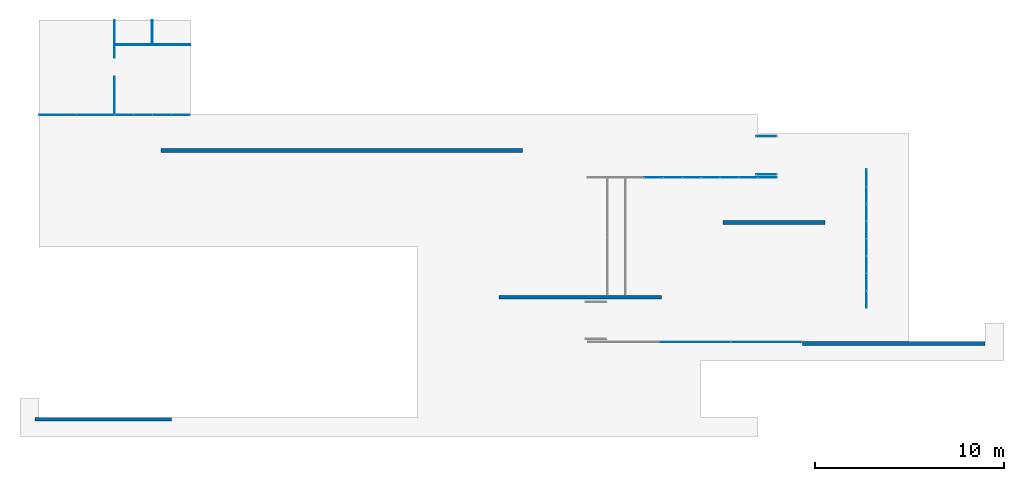
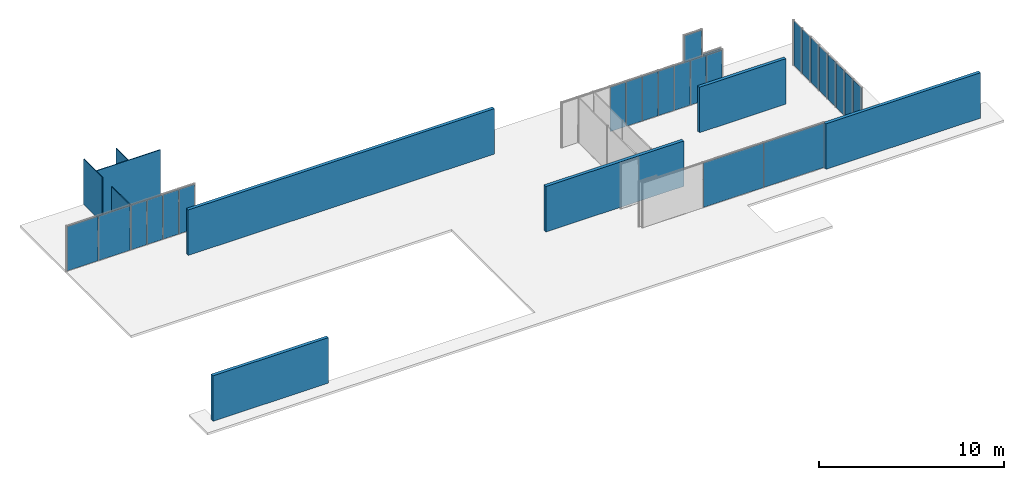
# One storey, part 8 of 8: 25 plates, 9 walls, 7 elements without a shape of their own.
"""IFC2X3 building model written with IfcOpenShell, lengths in millimetres."""

import ifcopenshell
import ifcopenshell.guid

model = None  # the IFC model being written
_history = None  # IfcOwnerHistory: only IFC2X3 demands one
_inside = {}  # id of a spatial element -> (the spatial element, [elements in it])
_under = {}  # id of a project, library or spatial element -> (it, [spatial elements below it])
_declared = {}  # id of a project -> (the project, [libraries it declares])
_typed = {}  # id of a type object -> (the type object, [elements of that type])
_made_of = {}  # id of a material, layer set ... -> (it, [elements and type objects made of it])


def new_model(schema):
    """Start an empty IFC model of exactly this schema.

    Asked for "IFC4X3", IfcOpenShell would pick the latest addendum, in which some entities
    have other attributes; the version numbers below select the first issue.
    IFC2X3 requires an IfcOwnerHistory on every rooted entity: one is made here for all.
    """
    global model, _history
    if schema == "IFC4X3":
        model = ifcopenshell.file(schema_version=(4, 3, 0, 0))
    else:
        model = ifcopenshell.file(schema=schema)
    _inside.clear()
    _under.clear()
    _declared.clear()
    _typed.clear()
    _made_of.clear()
    _history = None
    if model.schema == "IFC2X3":
        org = make("IfcOrganization", Name="unknown")
        user = make(
            "IfcPersonAndOrganization",
            ThePerson=make("IfcPerson", FamilyName="unknown"),
            TheOrganization=org,
        )
        app = make(
            "IfcApplication",
            ApplicationDeveloper=org,
            Version="unknown",
            ApplicationFullName="unknown",
            ApplicationIdentifier="unknown",
        )
        _history = make(
            "IfcOwnerHistory",
            OwningUser=user,
            OwningApplication=app,
            ChangeAction="ADDED",
            CreationDate=0,
        )
    return model


def make(cls, **values):
    """One entity of the class cls with the attributes given. An attribute that is None is left unset."""
    return model.create_entity(
        cls, **{name: value for name, value in values.items() if value is not None}
    )


def entity(cls, *values):
    """Any entity or typed value of the class cls, its attributes in the order of the schema. None: left unset."""
    e = model.create_entity(cls)
    for i, value in enumerate(values):
        if value is not None:
            e[i] = value
    return e


def rooted(cls, **values):
    """An entity with a GlobalId (a new one), such as an element, a storey or a relation."""
    return make(cls, GlobalId=ifcopenshell.guid.new(), OwnerHistory=_history, **values)


def si_unit(unit_type, name, prefix=None):
    """IfcSIUnit, for example si_unit("LENGTHUNIT", "METRE", prefix="MILLI")."""
    return make("IfcSIUnit", UnitType=unit_type, Prefix=prefix, Name=name)


def converted_unit(unit_type, name, factor, base, dimensions=None, offset=None):
    """IfcConversionBasedUnit, such as the inch: factor (a typed value) times the base unit."""
    return make(
        "IfcConversionBasedUnit"
        if offset is None
        else "IfcConversionBasedUnitWithOffset",
        ConversionOffset=offset,
        Dimensions=None
        if dimensions is None
        else entity("IfcDimensionalExponents", *dimensions),
        UnitType=unit_type,
        Name=name,
        ConversionFactor=make(
            "IfcMeasureWithUnit", ValueComponent=factor, UnitComponent=base
        ),
    )


def assignment(units):
    """IfcUnitAssignment: the units of a project."""
    return None if units is None else make("IfcUnitAssignment", Units=units)


def point(xyz):
    """IfcCartesianPoint."""
    return None if xyz is None else make("IfcCartesianPoint", Coordinates=xyz)


def direction(xyz):
    """IfcDirection."""
    return None if xyz is None else make("IfcDirection", DirectionRatios=xyz)


def frame(location, z_axis=None, x_axis=None):
    """IfcAxis2Placement3D, a coordinate frame: its origin and axes. An axis left out is left unset."""
    return make(
        "IfcAxis2Placement3D",
        Location=point(location),
        Axis=direction(z_axis),
        RefDirection=direction(x_axis),
    )


def frame_2d(location, x_axis=None):
    """IfcAxis2Placement2D, a coordinate frame in the plane: its origin and x axis."""
    return make(
        "IfcAxis2Placement2D", Location=point(location), RefDirection=direction(x_axis)
    )


def origin():
    """The frame at (0, 0, 0) with its axes left unset."""
    return frame((0.0, 0.0, 0.0))


def origin_2d_with_axis():
    """The frame at (0, 0) in the plane with the x axis (1, 0) written out."""
    return frame_2d((0.0, 0.0), x_axis=(1.0, 0.0))


def place(relative_to, where):
    """IfcLocalPlacement: puts the frame where relative to a parent placement (None: the world)."""
    return make(
        "IfcLocalPlacement", PlacementRelTo=relative_to, RelativePlacement=where
    )


def context(
    kind, dimensions, precision=None, world=None, true_north=None, identifier=None
):
    """IfcGeometricRepresentationContext, for example the 3D "Model" context."""
    return make(
        "IfcGeometricRepresentationContext",
        ContextIdentifier=identifier,
        ContextType=kind,
        CoordinateSpaceDimension=dimensions,
        Precision=precision,
        WorldCoordinateSystem=world,
        TrueNorth=true_north,
    )


def subcontext(parent, identifier, kind, view, scale=None):
    """IfcGeometricRepresentationSubContext, for example "Body" below "Model"."""
    return make(
        "IfcGeometricRepresentationSubContext",
        ContextIdentifier=identifier,
        ContextType=kind,
        ParentContext=parent,
        TargetScale=scale,
        TargetView=view,
    )


def project(units=None, contexts=None):
    """IfcProject with its units and contexts."""
    return rooted(
        "IfcProject",
        Name="project",
        RepresentationContexts=contexts,
        UnitsInContext=assignment(units),
    )


def spatial(cls, under=None, at=None, **own):
    """A site, building, storey or space (cls), placed at a placement, below another one or the project."""
    s = rooted(cls, ObjectPlacement=at, **own)
    if under is not None:
        _under.setdefault(under.id(), (under, []))[1].append(s)
    return s


def profile(cls, at=None, kind="AREA", **sizes):
    """A parametric profile (cls). Its sizes go by their IFC names, for example OverallWidth=200.0."""
    return make(cls, ProfileType=kind, Position=at, **sizes)


def rectangle(**sizes):
    """IfcRectangleProfileDef."""
    return profile("IfcRectangleProfileDef", **sizes)


def extrude(swept, where, along, depth):
    """IfcExtrudedAreaSolid: the profile swept, set in the frame where, extruded along a direction by depth."""
    return make(
        "IfcExtrudedAreaSolid",
        SweptArea=swept,
        Position=where,
        ExtrudedDirection=direction(along),
        Depth=depth,
    )


def shape(context_of_items, identifier, shape_type, items):
    """IfcShapeRepresentation: the items that make up one representation, for example the "Body"."""
    return make(
        "IfcShapeRepresentation",
        ContextOfItems=context_of_items,
        RepresentationIdentifier=identifier,
        RepresentationType=shape_type,
        Items=items,
    )


def source(mapping_origin, context_of_items, identifier, shape_type, items):
    """IfcRepresentationMap: a shape defined once, which mapped items show again and again."""
    return make(
        "IfcRepresentationMap",
        MappingOrigin=mapping_origin,
        MappedRepresentation=shape(context_of_items, identifier, shape_type, items),
    )


def transform(
    local_origin,
    x_axis=None,
    y_axis=None,
    z_axis=None,
    scale=None,
    scale2=None,
    scale3=None,
    uniform=True,
):
    """IfcCartesianTransformationOperator3D, or its non-uniform kind. x_axis, y_axis, z_axis: its Axis1, 2, 3."""
    if uniform:
        return make(
            "IfcCartesianTransformationOperator3D",
            Axis1=direction(x_axis),
            Axis2=direction(y_axis),
            LocalOrigin=point(local_origin),
            Scale=scale,
            Axis3=direction(z_axis),
        )
    return make(
        "IfcCartesianTransformationOperator3DnonUniform",
        Axis1=direction(x_axis),
        Axis2=direction(y_axis),
        LocalOrigin=point(local_origin),
        Scale=scale,
        Axis3=direction(z_axis),
        Scale2=scale2,
        Scale3=scale3,
    )


def mapped(mapping_source, mapping_target):
    """IfcMappedItem: shows the shape of a source again, moved by a transform."""
    return make(
        "IfcMappedItem", MappingSource=mapping_source, MappingTarget=mapping_target
    )


def material(Name=None, Category=None):
    """IfcMaterial."""
    return make("IfcMaterial", Name=Name, Category=Category)


def layer(
    of_material, thickness, ventilated=None, Name=None, Category=None, Priority=None
):
    """IfcMaterialLayer: one layer of a wall or slab, of a material (None: an air gap)."""
    return make(
        "IfcMaterialLayer",
        Material=of_material,
        LayerThickness=thickness,
        IsVentilated=ventilated,
        Name=Name,
        Category=Category,
        Priority=Priority,
    )


def layer_set(layers, Name=None):
    """IfcMaterialLayerSet."""
    return make("IfcMaterialLayerSet", MaterialLayers=layers, LayerSetName=Name)


def layer_usage(for_layer_set, set_direction, sense, offset, extent=None):
    """IfcMaterialLayerSetUsage: how a layer set lies in its element."""
    return make(
        "IfcMaterialLayerSetUsage",
        ForLayerSet=for_layer_set,
        LayerSetDirection=set_direction,
        DirectionSense=sense,
        OffsetFromReferenceLine=offset,
        ReferenceExtent=extent,
    )


def made_of(thing, what):
    """Note that an element or type object is made of a material, layer set ...; save() writes the relation."""
    if what is not None:
        _made_of.setdefault(what.id(), (what, []))[1].append(thing)
    return thing


def type_object(cls, material=None, **own):
    """A type object (cls), such as IfcWallType, which elements share."""
    return made_of(rooted(cls, **own), material)


def type_shapes(of_type, sources):
    """Give a type object the sources (RepresentationMaps) that its elements show as mapped items."""
    of_type.RepresentationMaps = sources


def element(
    cls,
    number,
    at=None,
    inside=None,
    cuts=None,
    type_object=None,
    material=None,
    context=None,
    identifier="Body",
    shape_type=None,
    held_by="IfcProductDefinitionShape",
    body=None,
    shapes=None,
    **own,
):
    """One element of the class cls, such as IfcWall. Its Tag is "e" and its number.

    at: its placement. inside: the storey or other place that contains it. cuts: it is an
    opening in that element (IfcRelVoidsElement). A single representation is given by context,
    identifier, shape_type and body (its items); several are given by shapes. held_by: the class
    of the entity that holds the representations. save() writes the other relations.
    """
    e = rooted(cls, Tag="e%d" % number, ObjectPlacement=at, **own)
    if body is not None:
        shapes = [shape(context, identifier, shape_type, body)]
    if shapes is not None:
        e.Representation = make(held_by, Representations=shapes)
    if inside is not None:
        _inside.setdefault(inside.id(), (inside, []))[1].append(e)
    if cuts is not None:
        rooted(
            "IfcRelVoidsElement", RelatingBuildingElement=cuts, RelatedOpeningElement=e
        )
    if type_object is not None:
        _typed.setdefault(type_object.id(), (type_object, []))[1].append(e)
    return made_of(e, material)


def aggregate(whole, parts):
    """IfcRelAggregates: a whole, such as a stair, and the parts it consists of."""
    return rooted("IfcRelAggregates", RelatingObject=whole, RelatedObjects=parts)


def save(model, path):
    """Write the relations noted so far, then the file.

    IfcRelAggregates (storeys below a building ...), IfcRelContainedInSpatialStructure (elements
    in a storey), IfcRelDefinesByType, IfcRelAssociatesMaterial and IfcRelDeclares: one each for
    every whole, place, type object, material and project.
    """
    for whole, parts in _under.values():
        aggregate(whole, parts)
    for where, things in _inside.values():
        rooted(
            "IfcRelContainedInSpatialStructure",
            RelatedElements=things,
            RelatingStructure=where,
        )
    for kind, things in _typed.values():
        rooted("IfcRelDefinesByType", RelatedObjects=things, RelatingType=kind)
    for what, things in _made_of.values():
        rooted("IfcRelAssociatesMaterial", RelatedObjects=things, RelatingMaterial=what)
    for by, libraries in _declared.values():
        rooted("IfcRelDeclares", RelatingContext=by, RelatedDefinitions=libraries)
    model.write(path)


model = new_model("IFC2X3")

# Units and contexts
model_context = context("Model", 3, precision=1e-06, world=origin(), true_north=direction((2.0, 6.12303176911189e-17, 1.0)))
context_of_model = context(None, 3, precision=1e-06, world=origin(), true_north=direction((2.0, 6.12303176911189e-17, 1.0)))
body_context = subcontext(model_context, "Body", "Model", "MODEL_VIEW")
ifc_project = project(units=[si_unit("LENGTHUNIT", "METRE", prefix="MILLI"), si_unit("AREAUNIT", "SQUARE_METRE", prefix="MILLI"), si_unit("VOLUMEUNIT", "CUBIC_METRE", prefix="MILLI"), converted_unit("PLANEANGLEUNIT", "DEGREE", entity("IfcRatioMeasure", 0.0174532925199433), si_unit("PLANEANGLEUNIT", "RADIAN"), dimensions=[0, 0, 0, 0, 0, 0, 0]), si_unit("TIMEUNIT", "SECOND")], contexts=[model_context, context_of_model])

# Site, building, storey
site_placement = place(None, origin())
site = spatial("IfcSite", under=ifc_project, at=site_placement, CompositionType="ELEMENT")
building_placement = place(site_placement, origin())
building = spatial("IfcBuilding", under=site, at=building_placement, CompositionType="ELEMENT")
storey_placement = place(building_placement, frame((0.0, 0.0, 1500.0)))
storey = spatial("IfcBuildingStorey", under=building, at=storey_placement, Name="Level 1", CompositionType="ELEMENT", Elevation=1500.0)

# Curtain wall, plates
curtain_wall_1_placement = place(storey_placement, origin())
curtain_wall_1 = element("IfcCurtainWall", 1, at=curtain_wall_1_placement, inside=storey, Name="Curtain Wall:Curtain Wall", ObjectType="Curtain Wall:Curtain Wall:334")
ifc_material_1 = material(Name="Glass")
plate_type_1 = type_object("IfcPlateType", Name="Glazed", PredefinedType="CURTAIN_PANEL")
shared_shape_1 = source(origin(), body_context, "Body", "SweptSolid", [
    extrude(rectangle(XDim=10.0, YDim=1936.24999999998, at=origin_2d_with_axis()), frame((0.0, 0.0, 0.0), z_axis=(0.0, 0.0, 1.0), x_axis=(0.0, 1.0, 0.0)), (0.0, 0.0, 1.0), 2940.0),
])
type_shapes(plate_type_1, [shared_shape_1])
plate_1_placement = place(storey_placement, frame((-24001.875, 5875.0, 30.0)))
plate_1 = element("IfcPlate", 2, at=plate_1_placement, type_object=plate_type_1, material=ifc_material_1, Name="Curtain Wall:Curtain Wall", ObjectType="Glazed", context=body_context, shape_type="MappedRepresentation", body=[
    mapped(shared_shape_1, transform((0.0, 0.0, 0.0), scale=1.0)),
])
plate_type_2 = type_object("IfcPlateType", Name="Glazed", PredefinedType="CURTAIN_PANEL")
shared_shape_2 = source(origin(), body_context, "Body", "SweptSolid", [
    extrude(rectangle(XDim=10.0, YDim=1966.24999999998, at=origin_2d_with_axis()), frame((0.0, 0.0, 0.0), z_axis=(0.0, 0.0, 1.0), x_axis=(0.0, 1.0, 0.0)), (0.0, 0.0, 1.0), 2940.0),
])
type_shapes(plate_type_2, [shared_shape_2])
plate_2_placement = place(storey_placement, frame((-22020.625, 5875.0, 30.0)))
plate_2 = element("IfcPlate", 3, at=plate_2_placement, type_object=plate_type_2, material=ifc_material_1, Name="Curtain Wall:Curtain Wall", ObjectType="Glazed", context=body_context, shape_type="MappedRepresentation", body=[
    mapped(shared_shape_2, transform((0.0, 0.0, 0.0), scale=1.0)),
])
aggregate(curtain_wall_1, [plate_1, plate_2])

curtain_wall_2_placement = place(storey_placement, origin())
curtain_wall_2 = element("IfcCurtainWall", 4, at=curtain_wall_2_placement, inside=storey, Name="Curtain Wall:Curtain Wall", ObjectType="Curtain Wall:Curtain Wall:334")
plate_type_3 = type_object("IfcPlateType", Name="Glazed", PredefinedType="CURTAIN_PANEL")
shared_shape_3 = source(origin(), body_context, "Body", "SweptSolid", [
    extrude(rectangle(XDim=10.0, YDim=971.874999999998, at=origin_2d_with_axis()), frame((0.0, 0.0, 0.0), z_axis=(0.0, 0.0, 1.0), x_axis=(0.0, 1.0, 0.0)), (0.0, 0.0, 1.0), 2940.0),
])
type_shapes(plate_type_3, [shared_shape_3])
plate_3_placement = place(storey_placement, frame((-20491.5625, 5875.0, 30.0)))
plate_3 = element("IfcPlate", 5, at=plate_3_placement, type_object=plate_type_3, material=ifc_material_1, Name="Curtain Wall:Curtain Wall", ObjectType="Glazed", context=body_context, shape_type="MappedRepresentation", body=[
    mapped(shared_shape_3, transform((0.0, 0.0, 0.0), scale=1.0)),
])
plate_4_placement = place(storey_placement, frame((-19489.6875, 5875.0, 30.0)))
plate_4 = element("IfcPlate", 6, at=plate_4_placement, type_object=plate_type_3, material=ifc_material_1, Name="Curtain Wall:Curtain Wall", ObjectType="Glazed", context=body_context, shape_type="MappedRepresentation", body=[
    mapped(shared_shape_3, transform((0.0, 0.0, 0.0), scale=1.0)),
])
plate_5_placement = place(storey_placement, frame((-18487.8125, 5875.0, 30.0)))
plate_5 = element("IfcPlate", 7, at=plate_5_placement, type_object=plate_type_3, material=ifc_material_1, Name="Curtain Wall:Curtain Wall", ObjectType="Glazed", context=body_context, shape_type="MappedRepresentation", body=[
    mapped(shared_shape_3, transform((0.0, 0.0, 0.0), scale=1.0)),
])
plate_type_4 = type_object("IfcPlateType", Name="Glazed", PredefinedType="CURTAIN_PANEL")
shared_shape_4 = source(origin(), body_context, "Body", "SweptSolid", [
    extrude(rectangle(XDim=10.0, YDim=941.874999999996, at=origin_2d_with_axis()), frame((0.0, 0.0, 0.0), z_axis=(0.0, 0.0, 1.0), x_axis=(0.0, 1.0, 0.0)), (0.0, 0.0, 1.0), 2940.0),
])
type_shapes(plate_type_4, [shared_shape_4])
plate_6_placement = place(storey_placement, frame((-17500.9375, 5875.0, 30.0)))
plate_6 = element("IfcPlate", 8, at=plate_6_placement, type_object=plate_type_4, material=ifc_material_1, Name="Curtain Wall:Curtain Wall", ObjectType="Glazed", context=body_context, shape_type="MappedRepresentation", body=[
    mapped(shared_shape_4, transform((0.0, 0.0, 0.0), scale=1.0)),
])
aggregate(curtain_wall_2, [plate_3, plate_4, plate_5, plate_6])

curtain_wall_3_placement = place(storey_placement, origin())
curtain_wall_3 = element("IfcCurtainWall", 9, at=curtain_wall_3_placement, inside=storey, Name="Curtain Wall:Curtain Wall", ObjectType="Curtain Wall:Curtain Wall:334")
plate_type_5 = type_object("IfcPlateType", Name="Glazed", PredefinedType="CURTAIN_PANEL")
shared_shape_5 = source(origin(), body_context, "Body", "SweptSolid", [
    extrude(rectangle(XDim=10.0, YDim=971.5, at=origin_2d_with_axis()), frame((0.0, 0.0, 0.0), z_axis=(0.0, 0.0, 1.0), x_axis=(0.0, 1.0, 0.0)), (0.0, 0.0, 1.0), 2940.0),
])
type_shapes(plate_type_5, [shared_shape_5])
plate_7_placement = place(storey_placement, frame((13506.75, 2575.0, 30.0), z_axis=(0.0, 0.0, 1.0), x_axis=(-1.0, 0.0, 0.0)))
plate_7 = element("IfcPlate", 10, at=plate_7_placement, type_object=plate_type_5, material=ifc_material_1, Name="Curtain Wall:Curtain Wall", ObjectType="Glazed", context=body_context, shape_type="MappedRepresentation", body=[
    mapped(shared_shape_5, transform((0.0, 0.0, 0.0), scale=1.0)),
])
plate_8_placement = place(storey_placement, frame((12505.25, 2575.0, 30.0), z_axis=(0.0, 0.0, 1.0), x_axis=(-1.0, 0.0, 0.0)))
plate_8 = element("IfcPlate", 11, at=plate_8_placement, type_object=plate_type_5, material=ifc_material_1, Name="Curtain Wall:Curtain Wall", ObjectType="Glazed", context=body_context, shape_type="MappedRepresentation", body=[
    mapped(shared_shape_5, transform((0.0, 0.0, 0.0), scale=1.0)),
])
plate_9_placement = place(storey_placement, frame((11503.75, 2575.0, 30.0), z_axis=(0.0, 0.0, 1.0), x_axis=(-1.0, 0.0, 0.0)))
plate_9 = element("IfcPlate", 12, at=plate_9_placement, type_object=plate_type_5, material=ifc_material_1, Name="Curtain Wall:Curtain Wall", ObjectType="Glazed", context=body_context, shape_type="MappedRepresentation", body=[
    mapped(shared_shape_5, transform((0.0, 0.0, 0.0), scale=1.0)),
])
plate_10_placement = place(storey_placement, frame((10502.25, 2575.0, 30.0), z_axis=(0.0, 0.0, 1.0), x_axis=(-1.0, 0.0, 0.0)))
plate_10 = element("IfcPlate", 13, at=plate_10_placement, type_object=plate_type_5, material=ifc_material_1, Name="Curtain Wall:Curtain Wall", ObjectType="Glazed", context=body_context, shape_type="MappedRepresentation", body=[
    mapped(shared_shape_5, transform((0.0, 0.0, 0.0), scale=1.0)),
])
plate_11_placement = place(storey_placement, frame((9500.75, 2575.0, 30.0), z_axis=(0.0, 0.0, 1.0), x_axis=(-1.0, 0.0, 0.0)))
plate_11 = element("IfcPlate", 14, at=plate_11_placement, type_object=plate_type_5, material=ifc_material_1, Name="Curtain Wall:Curtain Wall", ObjectType="Glazed", context=body_context, shape_type="MappedRepresentation", body=[
    mapped(shared_shape_5, transform((0.0, 0.0, 0.0), scale=1.0)),
])
plate_12_placement = place(storey_placement, frame((8499.25, 2575.0, 30.0), z_axis=(0.0, 0.0, 1.0), x_axis=(-1.0, 0.0, 0.0)))
plate_12 = element("IfcPlate", 15, at=plate_12_placement, type_object=plate_type_5, material=ifc_material_1, Name="Curtain Wall:Curtain Wall", ObjectType="Glazed", context=body_context, shape_type="MappedRepresentation", body=[
    mapped(shared_shape_5, transform((0.0, 0.0, 0.0), scale=1.0)),
])
plate_13_placement = place(storey_placement, frame((7497.75, 2575.0, 30.0), z_axis=(0.0, 0.0, 1.0), x_axis=(-1.0, 0.0, 0.0)))
plate_13 = element("IfcPlate", 16, at=plate_13_placement, type_object=plate_type_5, material=ifc_material_1, Name="Curtain Wall:Curtain Wall", ObjectType="Glazed", context=body_context, shape_type="MappedRepresentation", body=[
    mapped(shared_shape_5, transform((0.0, 0.0, 0.0), scale=1.0)),
])
aggregate(curtain_wall_3, [plate_7, plate_8, plate_9, plate_10, plate_11, plate_12, plate_13])

curtain_wall_4_placement = place(storey_placement, origin())
curtain_wall_4 = element("IfcCurtainWall", 17, at=curtain_wall_4_placement, inside=storey, Name="Curtain Wall:Curtain Wall", ObjectType="Curtain Wall:Curtain Wall:334")
plate_type_6 = type_object("IfcPlateType", Name="Glazed", PredefinedType="CURTAIN_PANEL")
shared_shape_6 = source(origin(), body_context, "Body", "SweptSolid", [
    extrude(rectangle(XDim=10.0, YDim=888.75, at=origin_2d_with_axis()), frame((0.0, 0.0, 0.0), z_axis=(0.0, 0.0, 1.0), x_axis=(0.0, 1.0, 0.0)), (0.0, 0.0, 1.0), 2940.0),
])
type_shapes(plate_type_6, [shared_shape_6])
plate_14_placement = place(storey_placement, frame((18734.4440927411, 2565.625, 30.0), z_axis=(0.0, 0.0, 1.0), x_axis=(0.0, -1.0, 0.0)))
plate_14 = element("IfcPlate", 18, at=plate_14_placement, type_object=plate_type_6, material=ifc_material_1, Name="Curtain Wall:Curtain Wall", ObjectType="Glazed", context=body_context, shape_type="MappedRepresentation", body=[
    mapped(shared_shape_6, transform((0.0, 0.0, 0.0), scale=1.0)),
])
plate_15_placement = place(storey_placement, frame((18734.4440927411, 1646.875, 30.0), z_axis=(0.0, 0.0, 1.0), x_axis=(0.0, -1.0, 0.0)))
plate_15 = element("IfcPlate", 19, at=plate_15_placement, type_object=plate_type_6, material=ifc_material_1, Name="Curtain Wall:Curtain Wall", ObjectType="Glazed", context=body_context, shape_type="MappedRepresentation", body=[
    mapped(shared_shape_6, transform((0.0, 0.0, 0.0), scale=1.0)),
])
plate_16_placement = place(storey_placement, frame((18734.4440927411, 728.125000000001, 30.0), z_axis=(0.0, 0.0, 1.0), x_axis=(0.0, -1.0, 0.0)))
plate_16 = element("IfcPlate", 20, at=plate_16_placement, type_object=plate_type_6, material=ifc_material_1, Name="Curtain Wall:Curtain Wall", ObjectType="Glazed", context=body_context, shape_type="MappedRepresentation", body=[
    mapped(shared_shape_6, transform((0.0, 0.0, 0.0), scale=1.0)),
])
plate_17_placement = place(storey_placement, frame((18734.4440927411, -190.625, 30.0), z_axis=(0.0, 0.0, 1.0), x_axis=(0.0, -1.0, 0.0)))
plate_17 = element("IfcPlate", 21, at=plate_17_placement, type_object=plate_type_6, material=ifc_material_1, Name="Curtain Wall:Curtain Wall", ObjectType="Glazed", context=body_context, shape_type="MappedRepresentation", body=[
    mapped(shared_shape_6, transform((0.0, 0.0, 0.0), scale=1.0)),
])
plate_18_placement = place(storey_placement, frame((18734.4440927411, -1109.375, 30.0), z_axis=(0.0, 0.0, 1.0), x_axis=(0.0, -1.0, 0.0)))
plate_18 = element("IfcPlate", 22, at=plate_18_placement, type_object=plate_type_6, material=ifc_material_1, Name="Curtain Wall:Curtain Wall", ObjectType="Glazed", context=body_context, shape_type="MappedRepresentation", body=[
    mapped(shared_shape_6, transform((0.0, 0.0, 0.0), scale=1.0)),
])
plate_19_placement = place(storey_placement, frame((18734.4440927411, -2028.125, 30.0), z_axis=(0.0, 0.0, 1.0), x_axis=(0.0, -1.0, 0.0)))
plate_19 = element("IfcPlate", 23, at=plate_19_placement, type_object=plate_type_6, material=ifc_material_1, Name="Curtain Wall:Curtain Wall", ObjectType="Glazed", context=body_context, shape_type="MappedRepresentation", body=[
    mapped(shared_shape_6, transform((0.0, 0.0, 0.0), scale=1.0)),
])
plate_20_placement = place(storey_placement, frame((18734.4440927411, -2946.875, 30.0), z_axis=(0.0, 0.0, 1.0), x_axis=(0.0, -1.0, 0.0)))
plate_20 = element("IfcPlate", 24, at=plate_20_placement, type_object=plate_type_6, material=ifc_material_1, Name="Curtain Wall:Curtain Wall", ObjectType="Glazed", context=body_context, shape_type="MappedRepresentation", body=[
    mapped(shared_shape_6, transform((0.0, 0.0, 0.0), scale=1.0)),
])
plate_21_placement = place(storey_placement, frame((18734.4440927411, -3865.625, 30.0), z_axis=(0.0, 0.0, 1.0), x_axis=(0.0, -1.0, 0.0)))
plate_21 = element("IfcPlate", 25, at=plate_21_placement, type_object=plate_type_6, material=ifc_material_1, Name="Curtain Wall:Curtain Wall", ObjectType="Glazed", context=body_context, shape_type="MappedRepresentation", body=[
    mapped(shared_shape_6, transform((0.0, 0.0, 0.0), scale=1.0)),
])
aggregate(curtain_wall_4, [plate_14, plate_15, plate_16, plate_17, plate_18, plate_19, plate_20, plate_21])

curtain_wall_5_placement = place(storey_placement, origin())
curtain_wall_5 = element("IfcCurtainWall", 26, at=curtain_wall_5_placement, inside=storey, Name="Curtain Wall:Curtain Wall", ObjectType="Curtain Wall:Curtain Wall:334")
plate_type_7 = type_object("IfcPlateType", Name="Glazed", PredefinedType="CURTAIN_PANEL")
shared_shape_7 = source(origin(), body_context, "Body", "SweptSolid", [
    extrude(rectangle(XDim=10.0, YDim=3746.66666666667, at=origin_2d_with_axis()), frame((0.0, 0.0, 0.0), z_axis=(0.0, 0.0, 1.0), x_axis=(0.0, 1.0, 0.0)), (0.0, 0.0, 1.0), 2940.0),
])
type_shapes(plate_type_7, [shared_shape_7])
plate_22_placement = place(storey_placement, frame((13446.6666666667, -6125.0, 30.0), z_axis=(0.0, 0.0, 1.0), x_axis=(-1.0, 0.0, 0.0)))
plate_22 = element("IfcPlate", 27, at=plate_22_placement, type_object=plate_type_7, material=ifc_material_1, Name="Curtain Wall:Curtain Wall", ObjectType="Glazed", context=body_context, shape_type="MappedRepresentation", body=[
    mapped(shared_shape_7, transform((0.0, 0.0, 0.0), scale=1.0)),
])
plate_23_placement = place(storey_placement, frame((9670.0, -6125.0, 30.0), z_axis=(0.0, 0.0, 1.0), x_axis=(-1.0, 0.0, 0.0)))
plate_23 = element("IfcPlate", 28, at=plate_23_placement, type_object=plate_type_7, material=ifc_material_1, Name="Curtain Wall:Curtain Wall", ObjectType="Glazed", context=body_context, shape_type="MappedRepresentation", body=[
    mapped(shared_shape_7, transform((0.0, 0.0, 0.0), scale=1.0)),
])
aggregate(curtain_wall_5, [plate_22, plate_23])

# Curtain wall, plate
curtain_wall_6_placement = place(storey_placement, origin())
curtain_wall_6 = element("IfcCurtainWall", 29, at=curtain_wall_6_placement, inside=storey, Name="Curtain Wall:Curtain Wall Zero Grid lines", ObjectType="Curtain Wall:Curtain Wall Zero Grid lines")
plate_type_8 = type_object("IfcPlateType", Name="Glazed", PredefinedType="CURTAIN_PANEL")
shared_shape_8 = source(origin(), body_context, "Body", "SweptSolid", [
    extrude(rectangle(XDim=10.0, YDim=1060.0, at=origin_2d_with_axis()), frame((0.0, 0.0, 0.0), z_axis=(0.0, 0.0, 1.0), x_axis=(0.0, 1.0, 0.0)), (0.0, 0.0, 1.0), 2940.0),
])
type_shapes(plate_type_8, [shared_shape_8])
plate_24_placement = place(storey_placement, frame((13445.0, 4755.0, 30.0)))
plate_24 = element("IfcPlate", 30, at=plate_24_placement, type_object=plate_type_8, material=ifc_material_1, Name="Curtain Wall:Curtain Wall Zero Grid lines", ObjectType="Glazed", context=body_context, shape_type="MappedRepresentation", body=[
    mapped(shared_shape_8, transform((0.0, 0.0, 0.0), scale=1.0)),
])
aggregate(curtain_wall_6, [plate_24])

curtain_wall_7_placement = place(storey_placement, origin())
curtain_wall_7 = element("IfcCurtainWall", 31, at=curtain_wall_7_placement, inside=storey, Name="Curtain Wall:Curtain Wall Zero Grid lines", ObjectType="Curtain Wall:Curtain Wall Zero Grid lines")
plate_25_placement = place(storey_placement, frame((13445.0, 2735.0, 30.0)))
plate_25 = element("IfcPlate", 32, at=plate_25_placement, type_object=plate_type_8, material=ifc_material_1, Name="Curtain Wall:Curtain Wall Zero Grid lines", ObjectType="Glazed", context=body_context, shape_type="MappedRepresentation", body=[
    mapped(shared_shape_8, transform((0.0, 0.0, 0.0), scale=1.0)),
])
aggregate(curtain_wall_7, [plate_25])

# Walls
ifc_material_2 = material(Name="Default Wall")
ifc_layer_1 = layer(ifc_material_2, 200.0)
ifc_layer_set_1 = layer_set([ifc_layer_1], Name="Basic Wall:Generic - 200mm")
ifc_layer_usage_1 = layer_usage(ifc_layer_set_1, "AXIS2", "NEGATIVE", 100.0)
wall_1_placement = place(storey_placement, frame((-18550.0, 4000.0, 0.0)))
element("IfcWallStandardCase", 33, at=wall_1_placement, inside=storey, material=ifc_layer_usage_1, Name="Basic Wall:Generic - 200mm", ObjectType="Basic Wall:Generic - 200mm:398", context=body_context, shape_type="SweptSolid", body=[
    extrude(rectangle(XDim=19100.0, YDim=200.0, at=frame_2d((9550.0, 0.0), x_axis=(-1.0, 0.0))), origin(), (0.0, 0.0, 1.0), 3000.0),
])
ifc_layer_usage_2 = layer_usage(ifc_layer_set_1, "AXIS2", "NEGATIVE", 100.0)
wall_2_placement = place(storey_placement, frame((25000.0, -6200.0, 0.0), z_axis=(0.0, 0.0, 1.0), x_axis=(-1.0, 0.0, 0.0)))
element("IfcWallStandardCase", 34, at=wall_2_placement, inside=storey, material=ifc_layer_usage_2, Name="Basic Wall:Generic - 200mm", ObjectType="Basic Wall:Generic - 200mm:398", context=body_context, shape_type="SweptSolid", body=[
    extrude(rectangle(XDim=9649.99999999998, YDim=200.0, at=frame_2d((4824.99999999999, -1.56319401867222e-13), x_axis=(-1.0, 0.0))), origin(), (0.0, 0.0, 1.0), 3000.0),
])
ifc_layer_usage_3 = layer_usage(ifc_layer_set_1, "AXIS2", "NEGATIVE", 100.0)
wall_3_placement = place(storey_placement, frame((-18000.0, -10200.0, 0.0), z_axis=(0.0, 0.0, 1.0), x_axis=(-1.0, 0.0, 0.0)))
element("IfcWallStandardCase", 35, at=wall_3_placement, inside=storey, material=ifc_layer_usage_3, Name="Basic Wall:Generic - 200mm", ObjectType="Basic Wall:Generic - 200mm:398", context=body_context, shape_type="SweptSolid", body=[
    extrude(rectangle(XDim=7200.0, YDim=199.999999999998, at=frame_2d((3600.0, 0.0), x_axis=(-1.0, 0.0))), origin(), (0.0, 0.0, 1.0), 3000.0),
])
ifc_layer_2 = layer(ifc_material_2, 50.0)
ifc_layer_set_2 = layer_set([ifc_layer_2], Name="Basic Wall:Generic - 50mm")
ifc_layer_usage_4 = layer_usage(ifc_layer_set_2, "AXIS2", "NEGATIVE", 25.0)
wall_4_placement = place(storey_placement, frame((-21007.5, 10900.0, 0.0), z_axis=(0.0, 0.0, 1.0), x_axis=(0.0, -1.0, 0.0)))
element("IfcWallStandardCase", 36, at=wall_4_placement, inside=storey, material=ifc_layer_usage_4, Name="Basic Wall:Generic - 50mm", ObjectType="Basic Wall:Generic - 50mm", context=body_context, shape_type="SweptSolid", body=[
    extrude(rectangle(XDim=1999.99999999998, YDim=49.9999999999973, at=frame_2d((999.999999999991, 0.0), x_axis=(-1.0, 0.0))), origin(), (0.0, 0.0, 1.0), 3000.0),
])
ifc_layer_usage_5 = layer_usage(ifc_layer_set_2, "AXIS2", "NEGATIVE", 25.0)
wall_5_placement = place(storey_placement, frame((-21007.5, 7900.0, 0.0), z_axis=(0.0, 0.0, 1.0), x_axis=(0.0, -1.0, 0.0)))
element("IfcWallStandardCase", 37, at=wall_5_placement, inside=storey, material=ifc_layer_usage_5, Name="Basic Wall:Generic - 50mm", ObjectType="Basic Wall:Generic - 50mm", context=body_context, shape_type="SweptSolid", body=[
    extrude(rectangle(XDim=1969.99999999999, YDim=49.9999999999973, at=frame_2d((984.999999999994, 0.0), x_axis=(-1.0, 0.0))), origin(), (0.0, 0.0, 1.0), 3000.0),
])
ifc_layer_usage_6 = layer_usage(ifc_layer_set_2, "AXIS2", "NEGATIVE", 25.0)
wall_6_placement = place(storey_placement, frame((-20982.5, 9595.0, 0.0)))
element("IfcWallStandardCase", 38, at=wall_6_placement, inside=storey, material=ifc_layer_usage_6, Name="Basic Wall:Generic - 50mm", ObjectType="Basic Wall:Generic - 50mm", context=body_context, shape_type="SweptSolid", body=[
    extrude(rectangle(XDim=3982.5, YDim=49.9999999999995, at=frame_2d((1991.25, 0.0), x_axis=(-1.0, 0.0))), origin(), (0.0, 0.0, 1.0), 3000.0),
])
ifc_layer_usage_7 = layer_usage(ifc_layer_set_2, "AXIS2", "NEGATIVE", 25.0)
wall_7_placement = place(storey_placement, frame((-19000.0, 9620.0, 0.0), z_axis=(0.0, 0.0, 1.0), x_axis=(0.0, 1.0, 0.0)))
element("IfcWallStandardCase", 39, at=wall_7_placement, inside=storey, material=ifc_layer_usage_7, Name="Basic Wall:Generic - 50mm", ObjectType="Basic Wall:Generic - 50mm", context=body_context, shape_type="SweptSolid", body=[
    extrude(rectangle(XDim=1279.99999999998, YDim=50.0000000000016, at=frame_2d((639.999999999992, 0.0), x_axis=(-1.0, 0.0))), origin(), (0.0, 0.0, 1.0), 3000.0),
])
ifc_layer_usage_8 = layer_usage(ifc_layer_set_1, "AXIS2", "NEGATIVE", 100.0)
wall_8_placement = place(storey_placement, frame((-700.0, -3750.0, 0.0)))
element("IfcWallStandardCase", 40, at=wall_8_placement, inside=storey, material=ifc_layer_usage_8, Name="Basic Wall:Generic - 200mm", ObjectType="Basic Wall:Generic - 200mm:398", context=body_context, shape_type="SweptSolid", body=[
    extrude(rectangle(XDim=8600.0, YDim=200.0, at=frame_2d((4300.0, 0.0), x_axis=(-1.0, 0.0))), origin(), (0.0, 0.0, 1.0), 3000.0),
])
ifc_layer_usage_9 = layer_usage(ifc_layer_set_1, "AXIS2", "NEGATIVE", 100.0)
wall_9_placement = place(storey_placement, frame((11150.0, 200.0, 0.0)))
element("IfcWallStandardCase", 41, at=wall_9_placement, inside=storey, material=ifc_layer_usage_9, Name="Basic Wall:Generic - 200mm", ObjectType="Basic Wall:Generic - 200mm:398", context=body_context, shape_type="SweptSolid", body=[
    extrude(rectangle(XDim=5400.0, YDim=200.0, at=frame_2d((2700.0, 0.0), x_axis=(-1.0, 0.0))), origin(), (0.0, 0.0, 1.0), 3000.0),
])

save(model, "model.ifc")
